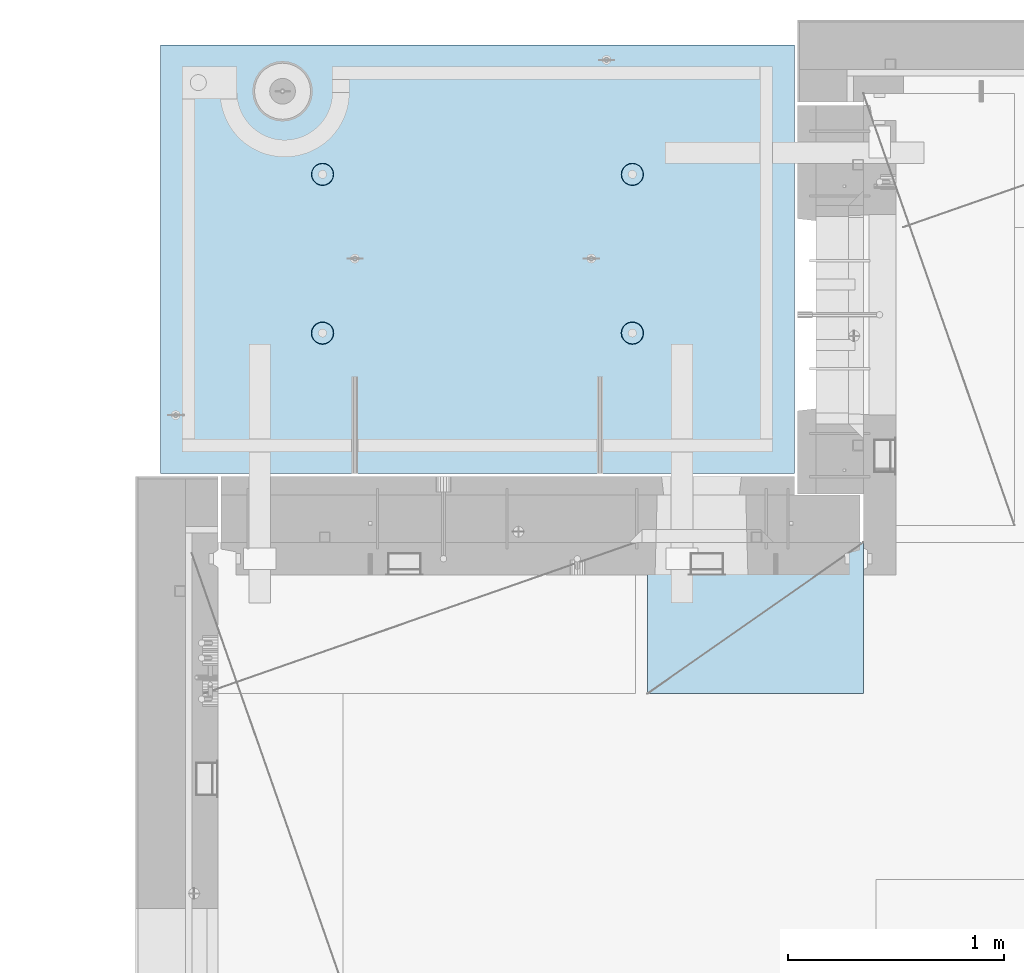
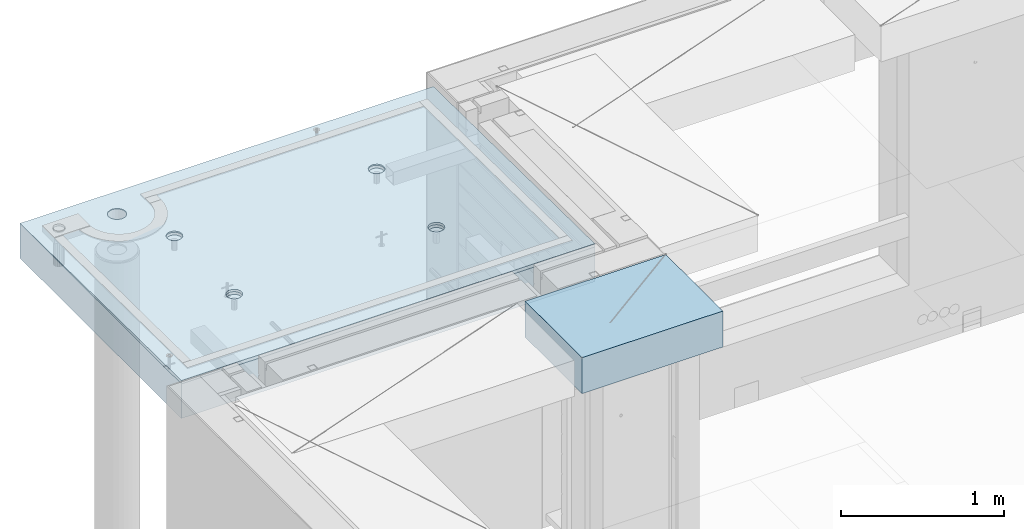
# One storey, part 198 of 334: 2 slabs, 1 plate, 2 elements without a shape of their own.
"""IFC2X3 building model written with IfcOpenShell, lengths in millimetres."""

from ifc_helpers import new_model, si_unit, frame, origin_with_axes, place, context, subcontext, project, spatial, faceted_brep, material, type_object, element, aggregate, save


model = new_model("IFC2X3")

# Units and contexts
model_context = context("Model", 3, precision=1e-05, world=origin_with_axes())
body_context = subcontext(model_context, "Body", "Model", "MODEL_VIEW")
ifc_project = project(units=[si_unit("LENGTHUNIT", "METRE", prefix="MILLI"), si_unit("AREAUNIT", "SQUARE_METRE"), si_unit("VOLUMEUNIT", "CUBIC_METRE"), si_unit("MASSUNIT", "GRAM", prefix="KILO"), si_unit("TIMEUNIT", "SECOND"), si_unit("PLANEANGLEUNIT", "RADIAN"), si_unit("SOLIDANGLEUNIT", "STERADIAN"), si_unit("THERMODYNAMICTEMPERATUREUNIT", "DEGREE_CELSIUS"), si_unit("LUMINOUSINTENSITYUNIT", "LUMEN")], contexts=[model_context])

# Site, building, storey
site_placement = place(None, origin_with_axes())
site = spatial("IfcSite", under=ifc_project, at=site_placement, CompositionType="ELEMENT")
building_placement = place(site_placement, origin_with_axes())
building = spatial("IfcBuilding", under=site, at=building_placement, CompositionType="ELEMENT")
storey_placement = place(building_placement, origin_with_axes())
storey = spatial("IfcBuildingStorey", under=building, at=storey_placement, Name="3", CompositionType="ELEMENT", Elevation=0.0)

# Assembly, slabs
assembly_1_placement = place(storey_placement, origin_with_axes())
assembly_1 = element("IfcElementAssembly", 1, at=assembly_1_placement, inside=storey, AssemblyPlace="NOTDEFINED", PredefinedType="REINFORCEMENT_UNIT")
ifc_material_1 = material(Name="CONCRETE/C35/45")
slab_type_1 = type_object("IfcSlabType", PredefinedType="NOTDEFINED")
slab_1_placement = place(assembly_1_placement, frame((7734.99985681325, 20899.9965573523, 90717.5), z_axis=(0.0, 1.0, 0.0), x_axis=(1.0, 0.0, 0.0)))
slab_1 = element("IfcSlab", 2, at=slab_1_placement, type_object=slab_type_1, material=ifc_material_1, PredefinedType="FLOOR", context=body_context, shape_type="Brep", body=[
    faceted_brep([(209.64691778923, 8.87688398158934, 1795.66138892724), (209.64691778923, 12.5000000975269, 1795.66138892724), (201.519156607756, 12.5000000956934, 1783.49470026561), (201.519156607756, 8.73204270274437, 1783.49470026561), (189.354094229504, 12.5000000940054, 1775.36450517907), (189.354094229504, 8.63525483493868, 1775.36450517907), (175.003751124998, 12.5000000927103, 1772.50855216914), (175.003751124998, 8.60125545370101, 1772.50855216914), (160.652836945715, 12.5000000920118, 1775.36163419229), (160.652836945715, 8.63522065659345, 1775.36163419229), (148.48614828409, 12.5000000919972, 1783.48939537376), (148.48614828409, 8.73197954936768, 1783.48939537376), (140.355953197546, 12.5000000926811, 1795.65445775201), (140.355953197546, 8.87680146773346, 1795.65445775201), (137.500000187611, 12.5000000939617, 1810.00480085652), (137.500000187611, 9.04763858744991, 1810.00480085652), (140.353082210766, 12.5000000956497, 1824.35571503581), (140.353082210766, 9.21848250564653, 1824.35571503581), (148.48084339224, 12.5000000974687, 1836.52240369743), (148.48084339224, 9.36332378449151, 1836.52240369743), (160.645905770492, 12.5000000991568, 1844.65259878397), (160.645905770492, 9.4601116522972, 1844.65259878397), (174.996248874998, 12.5000001004519, 1847.50855179391), (174.996248874998, 9.49411103353486, 1847.50855179391), (189.347163054282, 12.5000001011649, 1844.65546977075), (189.347163054282, 9.46014583064243, 1844.65546977075), (201.513851715907, 12.5000001011795, 1836.52770858928), (201.513851715907, 9.3633869378682, 1836.52770858928), (209.64404680245, 12.500000100481, 1824.36264621103), (209.64404680245, 9.21856501948787, 1824.36264621103), (212.499999812386, 12.5000000992004, 1810.01230310652), (212.499999812386, 9.04772789980052, 1810.01230310652), (0.0, 12.5, 1985.00366210938), (7.41420080885291e-08, 12.4999999999927, 0.0), (-7.41420080885291e-08, -12.5, -3.63797880709171e-12), (0.0, 11.1309547276614, 1985.00366210938), (2935.0, 12.5000004097383, 1985.00366209901), (2935.0, 11.1309547276614, 1985.00366210938), (2935.0, 12.5, 0.0), (2935.0, -12.5, 0.0), (2234.65136896188, -4.56985165992228, 666.133623356985), (2233.6850359994, 12.5000001221924, 665.819642744358), (2236.1904762364, 12.5000001207372, 650.000915653603), (2237.21797072983, -4.76190736876742, 650.000915653603), (2227.22763735012, -4.39666783543362, 680.68109000706), (2226.41396523543, 12.5000001231529, 680.089922611885), (2215.67536748502, -4.25927704213245, 692.221936790684), (2215.08900701139, 12.5000001235312, 691.414880835895), (2201.12537297611, -4.17108941465267, 699.629710429519), (2200.81872714385, 12.5000001232838, 698.685951599829), (2185.00000005312, -4.14070613867079, 702.181910066618), (2185.00000005312, 12.5000001224398, 701.19139183679), (2168.87462713012, -4.17108941465267, 699.629710429519), (2169.18127296234, 12.5000001210865, 698.685951599953), (2154.32463262121, -4.25927704213245, 692.221936790684), (2154.9109930947, 12.5000001193257, 691.414880836099), (2142.77236275611, -4.39666783543362, 680.68109000706), (2143.58603487053, 12.5000001173757, 680.089922612086), (2135.34863114435, -4.56985165992228, 666.133623356985), (2136.31496410644, 12.5000001153967, 665.819642744485), (2132.7820293764, -4.76190736876742, 650.000915653603), (2133.8095238694, 12.5000001135923, 650.000915653603), (2135.3268816397, -4.95404720651277, 633.861141107776), (2136.31496410626, 12.5000001121371, 634.182188562663), (2142.73717131393, -5.12745128343522, 619.29517322078), (2143.58603487023, 12.5000001111621, 619.911908694903), (2154.28944117357, -5.26511432380357, 607.731457644233), (2154.9109930944, 12.5000001107837, 608.586950470697), (2168.85287761663, -5.35352220384812, 600.305182758089), (2169.18127296215, 12.5000001110311, 601.315879706683), (2185.00000005312, -5.38398960883205, 597.745916272124), (2185.00000005312, 12.5000001118751, 598.810439469788), (2201.1471224896, -5.35352220384812, 600.305182758089), (2200.81872714404, 12.500000113243, 601.31587970681), (2215.71055893266, -5.26511432380357, 607.731457644233), (2215.08900701168, 12.5000001149892, 608.586950470901), (2227.2628287923, -5.12745128343522, 619.29517322078), (2226.41396523573, 12.5000001169392, 619.911908695103), (2234.67311846653, -4.95404720651277, 633.861141107776), (2233.68503599959, 12.5000001189328, 634.182188562787), (799.651368961879, -4.56985165992228, 666.133623356985), (798.685036005074, 12.5000000220316, 665.819642746203), (801.190476242367, 12.5000000205619, 650.000915653603), (802.217970729829, -4.76190736876742, 650.000915653603), (792.227637350119, -4.39666783543362, 680.68109000706), (791.41396524025, 12.500000022992, 680.089922615389), (780.675367485019, -4.25927704213245, 692.221936790684), (780.089007014889, 12.5000000233704, 691.414880840719), (766.125372976112, -4.17108941465267, 699.629710429519), (765.818727145695, 12.500000023123, 698.685951605497), (750.000000053116, -4.14070613867079, 702.181910066618), (750.000000053116, 12.500000022279, 701.191391842753), (733.874627130121, -4.17108941465267, 699.629710429519), (734.181272960497, 12.5000000209257, 698.685951605625), (719.324632621214, -4.25927704213245, 692.221936790684), (719.910993091196, 12.5000000191649, 691.414880840923), (707.772362756114, -4.39666783543362, 680.68109000706), (708.586034865702, 12.5000000172149, 680.089922615593), (700.348631144354, -4.56985165992228, 666.133623356985), (701.314964100775, 12.5000000152359, 665.819642746326), (697.782029376403, -4.76190736876742, 650.000915653603), (698.80952386344, 12.5000000134314, 650.000915653603), (700.326881639705, -4.95404720651277, 633.861141107776), (701.314964100589, 12.5000000119617, 634.182188560822), (707.737171313933, -5.12745128343522, 619.29517322078), (708.586034865404, 12.5000000110012, 619.911908691396), (719.289441173572, -5.26511432380357, 607.731457644233), (719.910993090896, 12.5000000106229, 608.586950465873), (733.852877616633, -5.35352220384812, 600.305182758089), (734.181272960313, 12.5000000108703, 601.315879701015), (750.000000053116, -5.38398960883205, 597.745916272124), (750.000000053116, 12.5000000117143, 598.810439463825), (766.1471224896, -5.35352220384812, 600.305182758089), (765.818727145879, 12.5000000130822, 601.315879701138), (780.71055893266, -5.26511432380357, 607.731457644233), (780.089007015189, 12.5000000148284, 608.586950466077), (792.2628287923, -5.12745128343522, 619.29517322078), (791.413965240548, 12.5000000167784, 619.9119086916), (799.673118466528, -4.95404720651277, 633.861141107776), (798.685036005258, 12.500000018772, 634.182188560946), (799.156135017123, 4.17823925742414, 1400.9745431382), (798.685035917459, 12.5000000978907, 1400.82147376184), (801.190476154532, 12.5000000964355, 1385.00274667064), (801.697136924844, 3.98809915517631, 1385.00274667064), (791.806449365287, 4.3496957076859, 1415.37691010137), (791.413965153277, 12.5000000988512, 1415.09175362977), (780.369404424282, 4.48571613449894, 1426.80264589727), (780.089006928914, 12.5000000992295, 1426.4167118541), (765.96453481571, 4.57302415884624, 1434.13653274457), (765.818727060978, 12.5000000989821, 1433.68778261824), (749.999999969796, 4.6031043852272, 1436.66327617152), (749.999999969796, 12.5000000981381, 1436.19322285528), (734.035465123881, 4.57302415884624, 1434.13653274457), (734.181272878572, 12.5000000967848, 1433.68778261837), (719.630595515309, 4.48571613449894, 1426.80264589727), (719.91099301053, 12.5000000950386, 1426.41671185431), (708.193550574304, 4.3496957076859, 1415.37691010137), (708.586034786036, 12.5000000930741, 1415.09175362997), (700.843864922468, 4.17823925742414, 1400.9745431382), (701.314964021747, 12.500000091095, 1400.82147376197), (698.302863014747, 3.98809915517631, 1385.00274667064), (698.809523784634, 12.500000089276, 1385.00274667064), (700.822332352242, 3.79787576314993, 1369.0239538469), (701.314964021563, 12.5000000878208, 1369.18401957925), (708.15871013944, 3.62620125728427, 1354.60327018229), (708.586034785736, 12.5000000868604, 1354.91373971109), (719.595755075041, 3.48991129887872, 1343.15489369192), (719.91099301023, 12.500000086482, 1343.58878148656), (734.013932544907, 3.40238521881111, 1335.80269013289), (734.181272878388, 12.5000000867294, 1336.31771072235), (749.999999969796, 3.37222170254972, 1333.26895034341), (749.999999969796, 12.5000000875589, 1333.81227048538), (765.986067394684, 3.40238521881111, 1335.80269013289), (765.818727061163, 12.5000000889413, 1336.31771072247), (780.40424486455, 3.48991129887872, 1343.15489369192), (780.089006929215, 12.500000090673, 1343.58878148677), (791.841289800152, 3.62620125728427, 1354.60327018229), (791.413965153577, 12.5000000926375, 1354.91373971129), (799.17766758735, 3.79787576314993, 1369.0239538469), (798.685035917644, 12.5000000946166, 1369.18401957938), (2234.15613501712, 4.17823925742414, 1400.9745431382), (2233.68503591179, 12.5000001980516, 1400.82147376), (2236.19047614857, 12.5000001965964, 1385.00274667064), (2236.69713692484, 3.98809915517631, 1385.00274667064), (2226.80644936529, 4.3496957076859, 1415.37691010137), (2226.41396514845, 12.5000001990265, 1415.09175362627), (2215.36940442428, 4.48571613449894, 1426.80264589727), (2215.08900692541, 12.5000001993903, 1426.41671184928), (2200.96453481571, 4.57302415884624, 1434.13653274457), (2200.81872705914, 12.5000001991575, 1433.68778261257), (2184.9999999698, 4.6031043852272, 1436.66327617152), (2184.9999999698, 12.5000001982989, 1436.19322284931), (2169.03546512388, 4.57302415884624, 1434.13653274457), (2169.18127288041, 12.5000001969456, 1433.6877826127), (2154.63059551531, 4.48571613449894, 1426.80264589727), (2154.91099301403, 12.5000001951994, 1426.41671184948), (2143.1935505743, 4.3496957076859, 1415.37691010137), (2143.58603479086, 12.5000001932349, 1415.09175362647), (2135.84386492247, 4.17823925742414, 1400.9745431382), (2136.31496402742, 12.5000001912558, 1400.82147376013), (2133.30286301475, 3.98809915517631, 1385.00274667064), (2133.8095237906, 12.5000001894368, 1385.00274667064), (2135.82233235224, 3.79787576314993, 1369.0239538469), (2136.31496402723, 12.5000001879816, 1369.18401958109), (2143.15871013944, 3.62620125728427, 1354.60327018229), (2143.58603479056, 12.5000001870212, 1354.91373971459), (2154.59575507504, 3.48991129887872, 1343.15489369192), (2154.91099301373, 12.5000001866429, 1343.58878149139), (2169.01393254491, 3.40238521881111, 1335.80269013289), (2169.18127288023, 12.5000001868902, 1336.31771072802), (2184.9999999698, 3.37222170254972, 1333.26895034341), (2184.9999999698, 12.5000001877343, 1333.81227049134), (2200.98606739468, 3.40238521881111, 1335.80269013289), (2200.81872705932, 12.5000001891021, 1336.31771072814), (2215.40424486455, 3.48991129887872, 1343.15489369192), (2215.08900692571, 12.5000001908338, 1343.58878149159), (2226.84128980015, 3.62620125728427, 1354.60327018229), (2226.41396514875, 12.5000001927983, 1354.9137397148), (2234.17766758735, 3.79787576314993, 1369.0239538469), (2233.68503591197, 12.5000001947919, 1369.18401958122), (613.539958053605, 8.15176414522284, 1734.75121634823), (600.266053528658, 7.99374174815603, 1721.47731182328), (583.539958053605, 7.89228512388945, 1712.95494050807), (564.998938391109, 7.85732555369032, 1710.01833148578), (546.457918728613, 7.89228512388945, 1712.95494050807), (529.73182325356, 7.99374174815603, 1721.47731182328), (516.457918728613, 8.15176414522284, 1734.75121634823), (507.935547413399, 8.35088398186781, 1751.47731182328), (504.998938391109, 8.57161002114299, 1770.01833148578), (507.935547413399, 8.79233606038906, 1788.55935114828), (516.457918728613, 8.99145589703403, 1805.28544662333), (529.73182325356, 9.1494782941154, 1818.55935114828), (546.457918728613, 9.25093491838197, 1827.08172246349), (564.998938391109, 9.28589448856656, 1830.01833148578), (583.539958053605, 9.25093491838197, 1827.08172246349), (600.266053528658, 9.1494782941154, 1818.55935114828), (613.539958053605, 8.99145589703403, 1805.28544662333), (622.062329368819, 8.79233606038906, 1788.55935114828), (624.998938391109, 8.57161002114299, 1770.01833148578), (622.062329368819, 8.35088398186781, 1751.47731182328), (613.539958053605, 12.5, 1805.28544662333), (622.062329368819, 12.5, 1788.55935114828), (600.266053528658, 12.5, 1818.55935114828), (583.539958053605, 12.5, 1827.08172246349), (564.998938391109, 12.5, 1830.01833148578), (546.457918728613, 12.5, 1827.08172246349), (529.73182325356, 12.5, 1818.55935114828), (516.457918728613, 12.5, 1805.28544662333), (507.935547413399, 12.5, 1788.55935114828), (504.998938391109, 12.5, 1770.01833148578), (507.935547413399, 12.5, 1751.47731182328), (516.457918728613, 12.5, 1734.75121634823), (529.73182325356, 12.5, 1721.47731182328), (546.457918728613, 12.5, 1712.95494050807), (564.998938391109, 12.5, 1710.01833148578), (583.539958053605, 12.5, 1712.95494050807), (600.266053528658, 12.5, 1721.47731182328), (613.539958053605, 12.5, 1734.75121634823), (622.062329368819, 12.5, 1751.47731182328), (624.998938391109, 12.5, 1770.01833148578)], [[[0, 1, 2, 3]], [[3, 2, 4, 5]], [[5, 4, 6, 7]], [[7, 6, 8, 9]], [[9, 8, 10, 11]], [[11, 10, 12, 13]], [[13, 12, 14, 15]], [[15, 14, 16, 17]], [[17, 16, 18, 19]], [[19, 18, 20, 21]], [[21, 20, 22, 23]], [[23, 22, 24, 25]], [[25, 24, 26, 27]], [[27, 26, 28, 29]], [[29, 28, 30, 31]], [[31, 30, 1, 0]], [[32, 33, 34, 35]], [[36, 32, 35, 37]], [[38, 36, 37, 39]], [[33, 38, 39, 34]], [[40, 41, 42, 43]], [[44, 45, 41, 40]], [[46, 47, 45, 44]], [[48, 49, 47, 46]], [[50, 51, 49, 48]], [[52, 53, 51, 50]], [[53, 52, 54, 55]], [[55, 54, 56, 57]], [[57, 56, 58, 59]], [[59, 58, 60, 61]], [[61, 60, 62, 63]], [[63, 62, 64, 65]], [[65, 64, 66, 67]], [[67, 66, 68, 69]], [[69, 68, 70, 71]], [[72, 73, 71, 70]], [[74, 75, 73, 72]], [[76, 77, 75, 74]], [[78, 79, 77, 76]], [[43, 42, 79, 78]], [[80, 81, 82, 83]], [[84, 85, 81, 80]], [[86, 87, 85, 84]], [[88, 89, 87, 86]], [[90, 91, 89, 88]], [[92, 93, 91, 90]], [[93, 92, 94, 95]], [[95, 94, 96, 97]], [[97, 96, 98, 99]], [[99, 98, 100, 101]], [[101, 100, 102, 103]], [[103, 102, 104, 105]], [[105, 104, 106, 107]], [[107, 106, 108, 109]], [[109, 108, 110, 111]], [[112, 113, 111, 110]], [[114, 115, 113, 112]], [[116, 117, 115, 114]], [[118, 119, 117, 116]], [[83, 82, 119, 118]], [[120, 121, 122, 123]], [[124, 125, 121, 120]], [[126, 127, 125, 124]], [[128, 129, 127, 126]], [[130, 131, 129, 128]], [[132, 133, 131, 130]], [[134, 135, 133, 132]], [[135, 134, 136, 137]], [[137, 136, 138, 139]], [[139, 138, 140, 141]], [[141, 140, 142, 143]], [[143, 142, 144, 145]], [[145, 144, 146, 147]], [[147, 146, 148, 149]], [[149, 148, 150, 151]], [[151, 150, 152, 153]], [[154, 155, 153, 152]], [[156, 157, 155, 154]], [[158, 159, 157, 156]], [[123, 122, 159, 158]], [[160, 161, 162, 163]], [[164, 165, 161, 160]], [[166, 167, 165, 164]], [[168, 169, 167, 166]], [[170, 171, 169, 168]], [[172, 173, 171, 170]], [[174, 175, 173, 172]], [[175, 174, 176, 177]], [[177, 176, 178, 179]], [[179, 178, 180, 181]], [[181, 180, 182, 183]], [[183, 182, 184, 185]], [[185, 184, 186, 187]], [[187, 186, 188, 189]], [[189, 188, 190, 191]], [[191, 190, 192, 193]], [[194, 195, 193, 192]], [[196, 197, 195, 194]], [[198, 199, 197, 196]], [[163, 162, 199, 198]], [[37, 35, 34, 39], [3, 5, 7, 9, 11, 13, 15, 17, 19, 21, 23, 25, 27, 29, 31, 0], [200, 201, 202, 203, 204, 205, 206, 207, 208, 209, 210, 211, 212, 213, 214, 215, 216, 217, 218, 219], [196, 194, 192, 190, 188, 186, 184, 182, 180, 178, 176, 174, 172, 170, 168, 166, 164, 160, 163, 198], [156, 154, 152, 150, 148, 146, 144, 142, 140, 138, 136, 134, 132, 130, 128, 126, 124, 120, 123, 158], [116, 114, 112, 110, 108, 106, 104, 102, 100, 98, 96, 94, 92, 90, 88, 86, 84, 80, 83, 118], [76, 74, 72, 70, 68, 66, 64, 62, 60, 58, 56, 54, 52, 50, 48, 46, 44, 40, 43, 78]], [[216, 220, 221, 217]], [[215, 222, 220, 216]], [[214, 223, 222, 215]], [[213, 224, 223, 214]], [[212, 225, 224, 213]], [[211, 226, 225, 212]], [[210, 227, 226, 211]], [[209, 228, 227, 210]], [[208, 229, 228, 209]], [[207, 230, 229, 208]], [[206, 231, 230, 207]], [[205, 232, 231, 206]], [[204, 233, 232, 205]], [[203, 234, 233, 204]], [[202, 235, 234, 203]], [[201, 236, 235, 202]], [[200, 237, 236, 201]], [[219, 238, 237, 200]], [[218, 239, 238, 219]], [[217, 221, 239, 218]], [[38, 33, 32, 36], [26, 24, 22, 20, 18, 16, 14, 12, 10, 8, 6, 4, 2, 1, 30, 28], [220, 222, 223, 224, 225, 226, 227, 228, 229, 230, 231, 232, 233, 234, 235, 236, 237, 238, 239, 221], [165, 167, 169, 171, 173, 175, 177, 179, 181, 183, 185, 187, 189, 191, 193, 195, 197, 199, 162, 161], [125, 127, 129, 131, 133, 135, 137, 139, 141, 143, 145, 147, 149, 151, 153, 155, 157, 159, 122, 121], [85, 87, 89, 91, 93, 95, 97, 99, 101, 103, 105, 107, 109, 111, 113, 115, 117, 119, 82, 81], [45, 47, 49, 51, 53, 55, 57, 59, 61, 63, 65, 67, 69, 71, 73, 75, 77, 79, 42, 41]]]),
])
slab_type_2 = type_object("IfcSlabType", PredefinedType="NOTDEFINED")
slab_2_placement = place(assembly_1_placement, frame((7734.99985681325, 20899.9965573523, 90575.0), z_axis=(-2.2639999995273e-06, 0.999999999997437, 0.0), x_axis=(0.999999999997251, 2.34499999952812e-06, 0.0)))
slab_2 = element("IfcSlab", 3, at=slab_2_placement, type_object=slab_type_2, material=ifc_material_1, PredefinedType="FLOOR", context=body_context, shape_type="Brep", body=[
    faceted_brep([(2200.45398600256, -110.0, 1337.44476079497), (2214.39241555253, -110.0, 1344.54670420538), (2225.45402859605, -110.0, 1355.60826537005), (2232.55603737762, -110.0, 1369.54666161175), (2235.0032477951, -110.0, 1384.99750559184), (2232.5561098421, -110.0, 1400.44836104917), (2225.45416643169, -110.0, 1414.38679059914), (2214.39260526702, -110.0, 1425.44840364265), (2200.45420902531, -110.0, 1432.55041242422), (2185.00336504523, -110.0, 1434.9976228417), (2169.55250958791, -110.0, 1432.55048488871), (2155.61408003793, -110.0, 1425.44854147829), (2144.55246699442, -110.0, 1414.38698031362), (2137.45045821285, -110.0, 1400.44858407192), (2135.00324779537, -110.0, 1384.99774009184), (2137.45038574836, -110.0, 1369.54688463451), (2144.55232915878, -110.0, 1355.60845508454), (2155.61389032345, -110.0, 1344.54684204102), (2169.55228656515, -110.0, 1337.44483325945), (2185.00313054523, -110.0, 1334.99762284198), (2226.41728354208, -130.0, 1415.08653268859), (2233.68832084322, -130.0, 1400.81623576839), (2215.09235187349, -130.0, 1426.41151747124), (2200.8220890546, -130.0, 1433.68262169999), (2185.0033678369, -130.0, 1436.18809903217), (2169.18463486868, -130.0, 1433.68269588982), (2154.91433794847, -130.0, 1426.41165858869), (2143.58935316583, -130.0, 1415.08672692009), (2136.31824893708, -130.0, 1400.81646410121), (2133.8127716049, -130.0, 1384.9977428835), (2136.31817474725, -130.0, 1369.17900991529), (2143.58921204838, -130.0, 1354.90871299508), (2154.91414371698, -130.0, 1343.58372821243), (2169.18440653586, -130.0, 1336.31262398369), (2185.00312775357, -130.0, 1333.8071466515), (2200.82186072178, -130.0, 1336.31254979386), (2215.09215764199, -130.0, 1343.58358709499), (2226.41714242464, -130.0, 1354.90851876358), (2233.68824665339, -130.0, 1369.17878158247), (2236.19372398557, -130.0, 1384.99750280017), (765.453986006505, -110.0, 1337.44812586997), (779.392415556478, -110.0, 1344.55006928038), (790.454028599992, -110.0, 1355.61163044505), (797.556037381562, -110.0, 1369.55002668675), (800.003247799041, -110.0, 1385.00087066684), (797.556109846048, -110.0, 1400.45172612417), (790.454166435635, -110.0, 1414.39015567414), (779.392605270965, -110.0, 1425.45176871765), (765.45420902926, -110.0, 1432.55377749922), (750.003365049179, -110.0, 1435.0009879167), (734.552509591851, -110.0, 1432.55384996371), (720.614080041878, -110.0, 1425.4519065533), (709.552466998364, -110.0, 1414.39034538862), (702.450458216794, -110.0, 1400.45194914692), (700.003247799315, -110.0, 1385.00110516684), (702.450385752309, -110.0, 1369.5502497095), (709.552329162721, -110.0, 1355.61182015954), (720.613890327391, -110.0, 1344.55020711602), (734.552286569096, -110.0, 1337.44819833446), (750.003130549179, -110.0, 1335.00098791698), (798.688320847163, -130.0, 1400.81960084339), (801.193723989514, -130.0, 1385.00086787517), (791.417283546027, -130.0, 1415.0898977636), (780.092351877434, -130.0, 1426.41488254624), (765.822089058547, -130.0, 1433.68598677499), (750.003367840845, -130.0, 1436.19146410717), (734.184634872629, -130.0, 1433.68606096482), (719.914337952418, -130.0, 1426.41502366369), (708.589353169771, -130.0, 1415.09009199509), (701.318248941023, -130.0, 1400.81982917621), (698.812771608842, -130.0, 1385.00110795851), (701.318174751194, -130.0, 1369.18237499029), (708.589212052329, -130.0, 1354.91207807008), (719.914143720922, -130.0, 1343.58709328743), (734.184406539811, -130.0, 1336.31598905868), (750.003127757513, -130.0, 1333.8105117265), (765.821860725729, -130.0, 1336.31591486885), (780.092157645939, -130.0, 1343.58695216999), (791.417142428585, -130.0, 1354.91188383858), (798.688246657333, -130.0, 1369.18214665747), (2935.0, -130.0, 1.16051523946226e-09), (0.0, -130.0, -3.63797880709171e-12), (0.0, 130.0, -1.81898940354586e-12), (2935.0, 130.0, 1.16051523946226e-09), (2935.00146484375, -130.0, 1985.00366210938), (2935.00146484375, 130.0, 1985.00366210938), (0.00127768016045593, -130.0, 1985.00366210937), (0.00127768016045593, 130.0, 1985.00366210937), (613.544191446293, 130.0, 1805.28400786653), (600.270318048689, 130.0, 1818.55794351875), (583.544242558642, 130.0, 1827.08035405663), (565.003229782545, 130.0, 1830.0170065576), (546.462203233751, 130.0, 1827.08044101401), (529.736087773786, 130.0, 1818.55810892152), (516.462152121568, 130.0, 1805.28423552391), (507.939741583684, 130.0, 1788.55816003387), (505.00308908271, 130.0, 1770.01714725777), (507.939654626302, 130.0, 1751.47612070897), (516.461986718798, 130.0, 1734.75000524901), (529.735860116402, 130.0, 1721.47606959679), (546.461935606448, 130.0, 1712.95365905891), (565.002948382545, 130.0, 1710.01700655793), (583.543974931338, 130.0, 1712.95357210152), (600.270090391306, 130.0, 1721.47590419402), (613.544026043523, 130.0, 1734.74977759163), (622.066436581407, 130.0, 1751.47585308167), (625.003089082381, 130.0, 1770.01686585777), (622.066523538789, 130.0, 1788.55789240656), (622.066523538789, -130.0, 1788.55789240656), (625.003089082381, -130.0, 1770.01686585777), (613.544191446293, -130.0, 1805.28400786653), (600.270318048689, -130.0, 1818.55794351875), (583.544242558642, -130.0, 1827.08035405663), (565.003229782545, -130.0, 1830.0170065576), (546.462203233751, -130.0, 1827.08044101401), (529.736087773786, -130.0, 1818.55810892152), (516.462152121568, -130.0, 1805.28423552391), (507.939741583684, -130.0, 1788.55816003387), (505.00308908271, -130.0, 1770.01714725777), (507.939654626302, -130.0, 1751.47612070897), (516.461986718798, -130.0, 1734.75000524901), (529.735860116402, -130.0, 1721.47606959679), (546.461935606448, -130.0, 1712.95365905891), (565.002948382545, -130.0, 1710.01700655793), (583.543974931338, -130.0, 1712.95357210152), (600.270090391306, -130.0, 1721.47590419402), (613.544026043523, -130.0, 1734.74977759163), (622.066436581407, -130.0, 1751.47585308167), (765.452262510529, -110.0, 602.446294854952), (779.390692060502, -110.0, 609.548238265361), (790.452305104016, -110.0, 620.609799430033), (797.554313885586, -110.0, 634.548195671738), (800.001524303065, -110.0, 649.999039651819), (797.554386350072, -110.0, 665.449895109152), (790.452442939657, -110.0, 679.388324659118), (779.390881774987, -110.0, 690.449937702637), (765.452485533282, -110.0, 697.551946484204), (750.001641553203, -110.0, 699.999156901682), (734.550786095873, -110.0, 697.552018948689), (720.6123565459, -110.0, 690.45007553828), (709.550743502386, -110.0, 679.388514373604), (702.448734720818, -110.0, 665.450118131903), (700.001524303339, -110.0, 649.999274151818), (702.448662256333, -110.0, 634.548418694489), (709.550605666745, -110.0, 620.609989144519), (720.612166831415, -110.0, 609.548376101004), (734.55056307312, -110.0, 602.446367319437), (750.001407053202, -110.0, 599.999156901958), (798.686597351187, -130.0, 665.817769828369), (801.192000493538, -130.0, 649.999036860154), (791.415560050051, -130.0, 680.088066748576), (780.090628381458, -130.0, 691.413051531228), (765.820365562571, -130.0, 698.684155759973), (750.001644344869, -130.0, 701.189633092159), (734.182911376653, -130.0, 698.684229949802), (719.912614456442, -130.0, 691.41319264867), (708.587629673795, -130.0, 680.088260980072), (701.316525445047, -130.0, 665.817998161187), (698.811048112866, -130.0, 649.999276943487), (701.316451255216, -130.0, 634.180543975268), (708.587488556352, -130.0, 619.910247055061), (719.912420224944, -130.0, 608.585262272412), (734.182683043833, -130.0, 601.314158043664), (750.001404261535, -130.0, 598.808680711485), (765.820137229752, -130.0, 601.314083853835), (780.090434149961, -130.0, 608.585121154971), (791.415418932607, -130.0, 619.910052823565), (798.686523161356, -130.0, 634.18031564245), (2200.45226250658, -110.0, 602.442929779951), (2214.39069205656, -110.0, 609.544873190363), (2225.45230510007, -110.0, 620.606434355035), (2232.55431388164, -110.0, 634.544830596737), (2235.00152429912, -110.0, 649.995674576818), (2232.55438634613, -110.0, 665.446530034151), (2225.45244293571, -110.0, 679.38495958412), (2214.39088177104, -110.0, 690.446572627639), (2200.45248552934, -110.0, 697.548581409203), (2185.00164154926, -110.0, 699.995791826681), (2169.55078609193, -110.0, 697.548653873688), (2155.61235654195, -110.0, 690.446710463279), (2144.55074349844, -110.0, 679.385149298603), (2137.44873471687, -110.0, 665.446753056905), (2135.00152429939, -110.0, 649.995909076821), (2137.44866225239, -110.0, 634.545053619491), (2144.5506056628, -110.0, 620.606624069518), (2155.61216682747, -110.0, 609.545011026003), (2169.55056306918, -110.0, 602.443002244436), (2185.00140704926, -110.0, 599.995791826957), (2233.68659734724, -130.0, 665.814404753368), (2236.19200048959, -130.0, 649.995671785153), (2226.41556004611, -130.0, 680.084701673575), (2215.09062837751, -130.0, 691.409686456227), (2200.82036555863, -130.0, 698.680790684972), (2185.00164434092, -130.0, 701.186268017158), (2169.18291137271, -130.0, 698.680864874805), (2154.9126144525, -130.0, 691.409827573672), (2143.58762966985, -130.0, 680.084895905075), (2136.3165254411, -130.0, 665.814633086189), (2133.81104810892, -130.0, 649.995911868486), (2136.31645125127, -130.0, 634.177178900271), (2143.58748855241, -130.0, 619.906881980063), (2154.912420221, -130.0, 608.581897197415), (2169.18268303989, -130.0, 601.310792968667), (2185.00140425759, -130.0, 598.805315636484), (2200.82013722581, -130.0, 601.310718778834), (2215.09043414602, -130.0, 608.58175607997), (2226.41541892866, -130.0, 619.906687748564), (2233.68652315741, -130.0, 634.176950567449)], [[[0, 1, 2, 3, 4, 5, 6, 7, 8, 9, 10, 11, 12, 13, 14, 15, 16, 17, 18, 19]], [[20, 6, 5, 21]], [[22, 7, 6, 20]], [[23, 8, 7, 22]], [[24, 9, 8, 23]], [[25, 10, 9, 24]], [[26, 11, 10, 25]], [[27, 12, 11, 26]], [[28, 13, 12, 27]], [[29, 14, 13, 28]], [[30, 15, 14, 29]], [[31, 16, 15, 30]], [[32, 17, 16, 31]], [[33, 18, 17, 32]], [[34, 19, 18, 33]], [[35, 0, 19, 34]], [[36, 1, 0, 35]], [[37, 2, 1, 36]], [[38, 3, 2, 37]], [[39, 4, 3, 38]], [[21, 5, 4, 39]], [[40, 41, 42, 43, 44, 45, 46, 47, 48, 49, 50, 51, 52, 53, 54, 55, 56, 57, 58, 59]], [[60, 45, 44, 61]], [[62, 46, 45, 60]], [[63, 47, 46, 62]], [[64, 48, 47, 63]], [[65, 49, 48, 64]], [[66, 50, 49, 65]], [[67, 51, 50, 66]], [[68, 52, 51, 67]], [[69, 53, 52, 68]], [[70, 54, 53, 69]], [[71, 55, 54, 70]], [[72, 56, 55, 71]], [[73, 57, 56, 72]], [[74, 58, 57, 73]], [[75, 59, 58, 74]], [[76, 40, 59, 75]], [[77, 41, 40, 76]], [[78, 42, 41, 77]], [[79, 43, 42, 78]], [[61, 44, 43, 79]], [[80, 81, 82, 83]], [[84, 80, 83, 85]], [[86, 84, 85, 87]], [[81, 86, 87, 82]], [[85, 83, 82, 87], [88, 89, 90, 91, 92, 93, 94, 95, 96, 97, 98, 99, 100, 101, 102, 103, 104, 105, 106, 107]], [[108, 107, 106, 109]], [[110, 88, 107, 108]], [[111, 89, 88, 110]], [[112, 90, 89, 111]], [[113, 91, 90, 112]], [[114, 92, 91, 113]], [[115, 93, 92, 114]], [[116, 94, 93, 115]], [[117, 95, 94, 116]], [[118, 96, 95, 117]], [[119, 97, 96, 118]], [[120, 98, 97, 119]], [[121, 99, 98, 120]], [[122, 100, 99, 121]], [[123, 101, 100, 122]], [[124, 102, 101, 123]], [[125, 103, 102, 124]], [[126, 104, 103, 125]], [[127, 105, 104, 126]], [[109, 106, 105, 127]], [[128, 129, 130, 131, 132, 133, 134, 135, 136, 137, 138, 139, 140, 141, 142, 143, 144, 145, 146, 147]], [[148, 133, 132, 149]], [[150, 134, 133, 148]], [[151, 135, 134, 150]], [[152, 136, 135, 151]], [[153, 137, 136, 152]], [[154, 138, 137, 153]], [[155, 139, 138, 154]], [[156, 140, 139, 155]], [[157, 141, 140, 156]], [[158, 142, 141, 157]], [[159, 143, 142, 158]], [[160, 144, 143, 159]], [[161, 145, 144, 160]], [[162, 146, 145, 161]], [[163, 147, 146, 162]], [[164, 128, 147, 163]], [[165, 129, 128, 164]], [[166, 130, 129, 165]], [[167, 131, 130, 166]], [[149, 132, 131, 167]], [[168, 169, 170, 171, 172, 173, 174, 175, 176, 177, 178, 179, 180, 181, 182, 183, 184, 185, 186, 187]], [[188, 173, 172, 189]], [[190, 174, 173, 188]], [[191, 175, 174, 190]], [[192, 176, 175, 191]], [[193, 177, 176, 192]], [[194, 178, 177, 193]], [[195, 179, 178, 194]], [[196, 180, 179, 195]], [[197, 181, 180, 196]], [[198, 182, 181, 197]], [[199, 183, 182, 198]], [[200, 184, 183, 199]], [[201, 185, 184, 200]], [[202, 186, 185, 201]], [[203, 187, 186, 202]], [[204, 168, 187, 203]], [[205, 169, 168, 204]], [[206, 170, 169, 205]], [[207, 171, 170, 206]], [[189, 172, 171, 207]], [[80, 84, 86, 81], [37, 36, 35, 34, 33, 32, 31, 30, 29, 28, 27, 26, 25, 24, 23, 22, 20, 21, 39, 38], [206, 205, 204, 203, 202, 201, 200, 199, 198, 197, 196, 195, 194, 193, 192, 191, 190, 188, 189, 207], [166, 165, 164, 163, 162, 161, 160, 159, 158, 157, 156, 155, 154, 153, 152, 151, 150, 148, 149, 167], [126, 125, 124, 123, 122, 121, 120, 119, 118, 117, 116, 115, 114, 113, 112, 111, 110, 108, 109, 127], [78, 77, 76, 75, 74, 73, 72, 71, 70, 69, 68, 67, 66, 65, 64, 63, 62, 60, 61, 79]]]),
])
aggregate(assembly_1, [slab_1, slab_2])

# Assembly, plate
assembly_2_placement = place(storey_placement, origin_with_axes())
assembly_2 = element("IfcElementAssembly", 4, at=assembly_2_placement, inside=storey, Name="Steel Assembly", AssemblyPlace="NOTDEFINED", PredefinedType="NOTDEFINED")
ifc_material_2 = material()
plate_type = type_object("IfcPlateType", PredefinedType="NOTDEFINED")
plate_placement = place(assembly_2_placement, frame((10990.0, 20580.0000000707, 90595.3), z_axis=(0.0, -1.0, 0.0), x_axis=(-1.0, 3.00000001838171e-08, 0.0)))
plate = element("IfcPlate", 5, at=plate_placement, type_object=plate_type, material=ifc_material_2, Name="RE1_1/2", context=body_context, shape_type="Brep", body=[
    faceted_brep([(1.81898940354586e-12, -135.0, 1.81898940354586e-12), (0.0, -135.0, 699.999999999996), (0.0, 135.0, 699.999999999996), (1.81898940354586e-12, 135.0, 1.81898940354586e-12), (999.99951171875, -135.0, 700.0), (999.99951171875, 135.0, 700.0), (1000.0, -135.0, 0.0), (1000.0, 135.0, 0.0)], [[[0, 1, 2, 3]], [[1, 4, 5, 2]], [[4, 6, 7, 5]], [[6, 0, 3, 7]], [[5, 7, 3, 2]], [[6, 4, 1, 0]]]),
])
aggregate(assembly_2, [plate])

save(model, "model.ifc")
